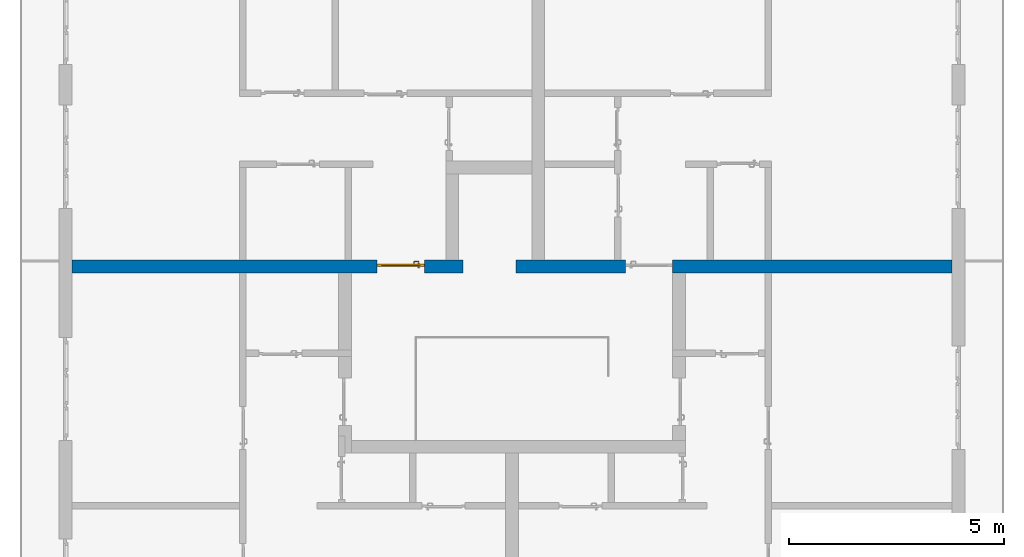
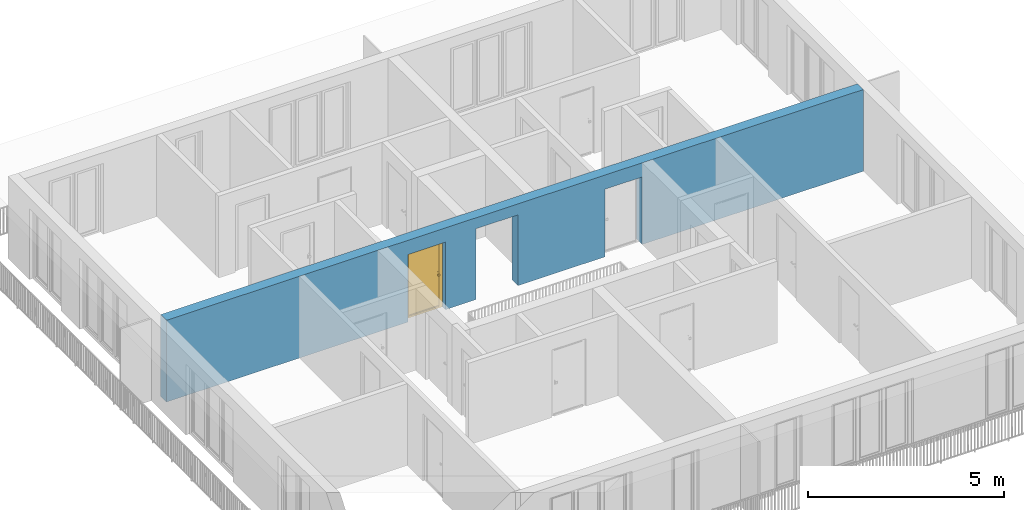
# One storey, part 16 of 54: 1 door, 1 wall, 3 openings.
"""IFC4 building model written with IfcOpenShell, lengths in metres."""

from ifc_helpers import new_model, entity, si_unit, converted_unit, derived_unit, direction, frame, origin_with_axes, place, context, subcontext, project, spatial, polygons, source, transform, mapped, material, type_object, element, fill, save


model = new_model("IFC4")

# Units and contexts
model_context = context("Model", 3, precision=1e-05, world=origin_with_axes(), true_north=direction((0.0, 1.0)))
body_context = subcontext(model_context, "Body", "Model", "MODEL_VIEW")
ifc_project = project(units=[si_unit("LENGTHUNIT", "METRE"), si_unit("AREAUNIT", "SQUARE_METRE"), si_unit("VOLUMEUNIT", "CUBIC_METRE"), converted_unit("PLANEANGLEUNIT", "DEGREE", entity("IfcPlaneAngleMeasure", 0.0174532925199), si_unit("PLANEANGLEUNIT", "RADIAN"), dimensions=[0, 0, 0, 0, 0, 0, 0]), converted_unit("TIMEUNIT", "Year", entity("IfcTimeMeasure", 31556926.0), si_unit("TIMEUNIT", "SECOND"), dimensions=[0, 0, 1, 0, 0, 0, 0]), si_unit("MASSUNIT", "GRAM", prefix="KILO"), si_unit("THERMODYNAMICTEMPERATUREUNIT", "DEGREE_CELSIUS"), si_unit("LUMINOUSINTENSITYUNIT", "LUMEN"), si_unit("ENERGYUNIT", "JOULE", prefix="MEGA"), derived_unit("THERMALCONDUCTANCEUNIT", [(si_unit("POWERUNIT", "WATT"), 1), (si_unit("LENGTHUNIT", "METRE"), -1), (si_unit("THERMODYNAMICTEMPERATUREUNIT", "KELVIN"), -1)]), derived_unit("SPECIFICHEATCAPACITYUNIT", [(si_unit("ENERGYUNIT", "JOULE"), 1), (si_unit("MASSUNIT", "GRAM", prefix="KILO"), -1), (si_unit("THERMODYNAMICTEMPERATUREUNIT", "KELVIN"), -1)]), derived_unit("MASSDENSITYUNIT", [(si_unit("MASSUNIT", "GRAM", prefix="KILO"), 1), (si_unit("VOLUMEUNIT", "CUBIC_METRE"), -1)])], contexts=[model_context])

# Site, building, storey
site_placement = place(None, origin_with_axes())
site = spatial("IfcSite", under=ifc_project, at=site_placement, CompositionType="ELEMENT")
building_placement = place(site_placement, origin_with_axes())
building = spatial("IfcBuilding", under=site, at=building_placement, CompositionType="ELEMENT")
storey_placement = place(building_placement, frame((0.0, 0.0, 9.18), z_axis=(0.0, 0.0, 1.0), x_axis=(1.0, 0.0, 0.0)))
storey = spatial("IfcBuildingStorey", under=building, at=storey_placement, Name="3. Geschoss", CompositionType="ELEMENT", Elevation=9.18)

# Wall, openings, door
ifc_material = material()
wall_type = type_object("IfcWallType", Name="300", PredefinedType="NOTDEFINED")
wall_placement = place(storey_placement, frame((-11.7421993804, 1.37118776896, 0.0), z_axis=(0.0, 0.0, 1.0), x_axis=(1.0, 0.0, 0.0)))
wall = element("IfcWall", 1, at=wall_placement, inside=storey, type_object=wall_type, material=ifc_material, Name="Wand-001", PredefinedType="NOTDEFINED", context=body_context, shape_type="Tessellation", body=[
    polygons([(9.4, 0.3, 2.2), (9.4, 0.3, 0.0), (8.5, 0.3, 0.0), (8.5, 0.3, 2.1), (7.4, 0.3, 2.1), (7.4, 0.3, 0.0), (0.3, 0.3, 0.0), (0.3, 0.3, 2.54), (20.78, 0.3, 2.54), (20.78, 0.3, 0.0), (14.28, 0.3, 0.0), (14.28, 0.3, 2.1), (13.18, 0.3, 2.1), (13.18, 0.3, 0.0), (10.63, 0.3, 0.0), (10.63, 0.3, 2.2), (9.4, 0.0, 2.2), (9.4, 0.0, 0.0), (8.5, 0.0, 0.0), (8.5, 0.0, 2.1), (7.4, 0.0, 2.1), (7.4, 0.0, 0.0), (0.3, 0.0, 0.0), (0.3, 0.0, 2.54), (20.78, 0.0, 2.54), (20.78, 0.0, 0.0), (14.28, 0.0, 0.0), (14.28, 0.0, 2.1), (13.18, 0.0, 2.1), (13.18, 0.0, 0.0), (10.63, 0.0, 0.0), (10.63, 0.0, 2.2)], [[[1, 2, 3, 4, 5, 6, 7, 8, 9, 10, 11, 12, 13, 14, 15, 16]], [[2, 1, 17, 18]], [[2, 18, 19, 3]], [[20, 4, 3, 19]], [[21, 5, 4, 20]], [[22, 6, 5, 21]], [[7, 6, 22, 23]], [[24, 8, 7, 23]], [[25, 9, 8, 24]], [[9, 25, 26, 10]], [[10, 26, 27, 11]], [[11, 27, 28, 12]], [[12, 28, 29, 13]], [[13, 29, 30, 14]], [[31, 15, 14, 30]], [[16, 15, 31, 32]], [[1, 16, 32, 17]], [[32, 31, 30, 29, 28, 27, 26, 25, 24, 23, 22, 21, 20, 19, 18, 17]]], closed=True),
])
opening_1_placement = place(wall_placement, frame((7.95, 0.0, 0.0), z_axis=(0.0, 0.0, 1.0), x_axis=(1.0, 0.0, 0.0)))
opening_1 = element("IfcOpeningElement", 2, at=opening_1_placement, cuts=wall, context=body_context, identifier="Reference", shape_type="Tessellation", body=[
    polygons([(0.55, 0.15, 0.0), (0.55, 0.15, 2.1), (0.55, -0.001, 2.1), (0.55, -0.001, 0.0), (0.55, 0.301, 0.0), (0.55, 0.301, 2.1), (-0.55, 0.15, 2.1), (-0.55, -0.001, 2.1), (-0.55, 0.301, 2.1), (-0.55, -0.001, 0.0), (-0.55, 0.15, 0.0), (-0.55, 0.301, 0.0)], [[[1, 2, 3, 4]], [[2, 1, 5, 6]], [[7, 8, 3, 2, 6, 9]], [[8, 10, 4, 3]], [[1, 4, 10, 11, 12, 5]], [[6, 5, 12, 9]], [[7, 11, 10, 8]], [[11, 7, 9, 12]]], closed=True),
])
opening_2_placement = place(wall_placement, frame((13.73, 0.0, 0.0), z_axis=(0.0, 0.0, 1.0), x_axis=(1.0, 0.0, 0.0)))
element("IfcOpeningElement", 3, at=opening_2_placement, cuts=wall, context=body_context, identifier="Reference", shape_type="Tessellation", body=[
    polygons([(0.55, 0.15, 0.0), (0.55, 0.15, 2.1), (0.55, -0.001, 2.1), (0.55, -0.001, 0.0), (0.55, 0.301, 0.0), (0.55, 0.301, 2.1), (-0.55, 0.15, 2.1), (-0.55, -0.001, 2.1), (-0.55, 0.301, 2.1), (-0.55, -0.001, 0.0), (-0.55, 0.15, 0.0), (-0.55, 0.301, 0.0)], [[[1, 2, 3, 4]], [[2, 1, 5, 6]], [[7, 8, 3, 2, 6, 9]], [[8, 10, 4, 3]], [[1, 4, 10, 11, 12, 5]], [[6, 5, 12, 9]], [[7, 11, 10, 8]], [[11, 7, 9, 12]]], closed=True),
])
opening_3_placement = place(wall_placement, frame((10.015, 0.0, 0.0), z_axis=(0.0, 0.0, 1.0), x_axis=(1.0, 0.0, 0.0)))
element("IfcOpeningElement", 4, at=opening_3_placement, cuts=wall, context=body_context, identifier="Reference", shape_type="Tessellation", body=[
    polygons([(-0.615, -0.001, 2.2), (-0.615, -0.001, 0.0), (0.615, -0.001, 0.0), (0.615, -0.001, 2.2), (-0.615, 0.301, 2.2), (-0.615, 0.301, 0.0), (0.615, 0.301, 0.0), (0.615, 0.301, 2.2)], [[[1, 2, 3, 4]], [[5, 6, 2, 1]], [[6, 7, 3, 2]], [[7, 8, 4, 3]], [[8, 5, 1, 4]], [[7, 6, 5, 8]]], closed=True),
])
door_type = type_object("IfcDoorType", Name="Eingang 01 1-Fl 26", OperationType="SINGLE_SWING_LEFT", PredefinedType="DOOR")
shared_shape = source(origin_with_axes(), body_context, "Body", "Tessellation", [
    polygons([(-0.55, -0.05, 0.0), (-0.55, -0.05, 2.1), (-0.55, -0.03, 2.1), (-0.55, -0.03, 0.0), (-0.45, -0.05, 0.0), (-0.45, -0.05, 2.0), (-0.1301, -0.05, 2.0), (-0.0001, -0.05, 2.0), (0.45, -0.05, 2.0), (0.45, -0.05, 0.0), (0.55, -0.05, 0.0), (0.55, -0.05, 2.1), (0.55, -0.03, 2.1), (0.55, -0.03, 0.0), (0.45, -0.03, 0.0), (0.45, -0.03, 2.0), (-0.0001, -0.03, 2.0), (-0.1301, -0.03, 2.0), (-0.45, -0.03, 2.0), (-0.45, -0.03, 0.0)], [[[1, 2, 3, 4]], [[1, 5, 6, 7, 8, 9, 10, 11, 12, 2]], [[2, 12, 13, 3]], [[4, 3, 13, 14, 15, 16, 17, 18, 19, 20]], [[5, 1, 4, 20]], [[6, 5, 20, 19]], [[7, 6, 19, 18]], [[8, 7, 18, 17]], [[9, 8, 17, 16]], [[10, 9, 16, 15]], [[11, 10, 15, 14]], [[12, 11, 14, 13]]], closed=True),
    polygons([(-0.55, -0.03, 0.0), (-0.55, -0.03, 2.1), (-0.55, 0.0, 2.1), (-0.55, 0.0, 0.0), (-0.48, -0.03, 0.0), (-0.48, -0.03, 2.03), (-0.1001, -0.03, 2.03), (-0.0301, -0.03, 2.03), (0.48, -0.03, 2.03), (0.48, -0.03, 0.0), (0.55, -0.03, 0.0), (0.55, -0.03, 2.1), (0.55, 0.0, 2.1), (0.55, 0.0, 0.0), (0.48, 0.0, 0.0), (0.48, 0.0, 2.03), (-0.0301, 0.0, 2.03), (-0.1001, 0.0, 2.03), (-0.48, 0.0, 2.03), (-0.48, 0.0, 0.0)], [[[1, 2, 3, 4]], [[1, 5, 6, 7, 8, 9, 10, 11, 12, 2]], [[2, 12, 13, 3]], [[4, 3, 13, 14, 15, 16, 17, 18, 19, 20]], [[5, 1, 4, 20]], [[6, 5, 20, 19]], [[7, 6, 19, 18]], [[8, 7, 18, 17]], [[9, 8, 17, 16]], [[10, 9, 16, 15]], [[11, 10, 15, 14]], [[12, 11, 14, 13]]], closed=True),
    polygons([(-0.48, 0.01, 0.0), (-0.48, 0.01, 2.03), (0.48, 0.01, 2.03), (0.48, 0.01, 0.0), (-0.48, -0.03, 0.0), (-0.48, -0.03, 2.03), (0.48, -0.03, 2.03), (0.48, -0.03, 0.0)], [[[1, 2, 3, 4]], [[1, 5, 6, 2]], [[2, 6, 7, 3]], [[3, 7, 8, 4]], [[4, 8, 5, 1]], [[8, 7, 6, 5]]], closed=True),
    polygons([(-0.445, -0.05, 0.0), (0.445, -0.05, 0.0), (0.445, -0.05, 0.05), (-0.445, -0.05, 0.05), (-0.445, -0.03, 0.0), (0.445, -0.03, 0.0), (0.445, -0.03, 0.07), (0.445, -0.035, 0.07), (-0.445, -0.035, 0.07), (-0.445, -0.03, 0.07)], [[[1, 2, 3, 4]], [[5, 6, 2, 1]], [[2, 6, 7, 8, 3]], [[4, 3, 8, 9]], [[1, 4, 9, 10, 5]], [[10, 7, 6, 5]], [[9, 8, 7, 10]]], closed=True),
    polygons([(0.4335, 0.02, 1.0733826859), (0.42, 0.02, 1.077), (0.42, 0.0199, 1.077), (0.4335, 0.0199, 1.0733826859), (0.443382685902, 0.02, 1.0635), (0.447, 0.02, 1.05), (0.443382685902, 0.02, 1.0365), (0.4335, 0.02, 1.0266173141), (0.42, 0.02, 1.023), (0.4065, 0.02, 1.0266173141), (0.396617314098, 0.02, 1.0365), (0.393, 0.02, 1.05), (0.396617314098, 0.02, 1.0635), (0.4065, 0.02, 1.0733826859), (0.4065, 0.0199, 1.0733826859), (0.42, 0.0101, 1.077), (0.4335, 0.0101, 1.0733826859), (0.443382685902, 0.0199, 1.0635), (0.447, 0.0199, 1.05), (0.443382685902, 0.0199, 1.0365), (0.4335, 0.0199, 1.0266173141), (0.42, 0.0199, 1.023), (0.4065, 0.0199, 1.0266173141), (0.396617314098, 0.0199, 1.0365), (0.393, 0.0199, 1.05), (0.396617314098, 0.0199, 1.0635), (0.4065, 0.0101, 1.0733826859), (0.42, 0.01, 1.077), (0.4335, 0.01, 1.0733826859), (0.443382685902, 0.0101, 1.0635), (0.447, 0.0101, 1.05), (0.443382685902, 0.0101, 1.0365), (0.4335, 0.0101, 1.0266173141), (0.42, 0.0101, 1.023), (0.4065, 0.0101, 1.0266173141), (0.396617314098, 0.0101, 1.0365), (0.393, 0.0101, 1.05), (0.396617314098, 0.0101, 1.0635), (0.4065, 0.01, 1.0733826859), (0.396617314098, 0.01, 1.0635), (0.393, 0.01, 1.05), (0.396617314098, 0.01, 1.0365), (0.4065, 0.01, 1.0266173141), (0.42, 0.01, 1.023), (0.4335, 0.01, 1.0266173141), (0.443382685902, 0.01, 1.0365), (0.447, 0.01, 1.05), (0.443382685902, 0.01, 1.0635)], [[[1, 2, 3, 4]], [[2, 1, 5, 6, 7, 8, 9, 10, 11, 12, 13, 14]], [[2, 14, 15, 3]], [[4, 3, 16, 17]], [[5, 1, 4, 18]], [[6, 5, 18, 19]], [[7, 6, 19, 20]], [[8, 7, 20, 21]], [[9, 8, 21, 22]], [[10, 9, 22, 23]], [[11, 10, 23, 24]], [[12, 11, 24, 25]], [[13, 12, 25, 26]], [[14, 13, 26, 15]], [[3, 15, 27, 16]], [[17, 16, 28, 29]], [[18, 4, 17, 30]], [[19, 18, 30, 31]], [[20, 19, 31, 32]], [[21, 20, 32, 33]], [[22, 21, 33, 34]], [[23, 22, 34, 35]], [[24, 23, 35, 36]], [[25, 24, 36, 37]], [[26, 25, 37, 38]], [[15, 26, 38, 27]], [[16, 27, 39, 28]], [[28, 39, 40, 41, 42, 43, 44, 45, 46, 47, 48, 29]], [[30, 17, 29, 48]], [[31, 30, 48, 47]], [[32, 31, 47, 46]], [[33, 32, 46, 45]], [[34, 33, 45, 44]], [[35, 34, 44, 43]], [[36, 35, 43, 42]], [[37, 36, 42, 41]], [[38, 37, 41, 40]], [[27, 38, 40, 39]]], closed=True),
    polygons([(0.412532169224, 0.019, 0.959692280177), (0.413279754556, 0.019, 0.961639806549), (0.40705, 0.019, 0.972430057958), (0.397569942042, 0.019, 0.96295), (0.415, 0.019, 0.952886751346), (0.415, 0.019, 0.9544), (0.412532169224, 0.02, 0.959692280177), (0.413279754556, 0.02, 0.961639806549), (0.414624817685, 0.02, 0.965143815798), (0.414624817685, 0.019, 0.965143815798), (0.42, 0.019, 0.967425445323), (0.42, 0.019, 0.9759), (0.407, 0.019, 0.972516660498), (0.397483339502, 0.019, 0.963), (0.415, 0.019, 0.95), (0.3941, 0.019, 0.95), (0.415, 0.019, 0.947113248654), (0.415, 0.019, 0.941339745962), (0.415, 0.019, 0.9375), (0.415, 0.02, 0.9375), (0.415, 0.02, 0.941339745962), (0.415, 0.02, 0.947113248654), (0.415, 0.02, 0.95), (0.415, 0.02, 0.952886751346), (0.415, 0.02, 0.9544), (0.396703916638, 0.02, 0.96345), (0.40655, 0.02, 0.973296083362), (0.42, 0.02, 0.9769), (0.42, 0.02, 0.967425445323), (0.425375182315, 0.019, 0.965143815798), (0.426720245444, 0.019, 0.961639806549), (0.43295, 0.019, 0.972430057958), (0.42, 0.019, 0.976), (0.407, 0.0189, 0.972516660498), (0.397483339502, 0.0189, 0.963), (0.394, 0.019, 0.95), (0.397569942042, 0.019, 0.93705), (0.40705, 0.019, 0.927569942042), (0.42, 0.019, 0.9241), (0.42, 0.019, 0.9325), (0.416464466094, 0.019, 0.933964466094), (0.416464466094, 0.02, 0.933964466094), (0.42, 0.02, 0.9231), (0.40655, 0.02, 0.926703916638), (0.42, 0.02, 0.9325), (0.396703916638, 0.02, 0.93655), (0.3931, 0.02, 0.95), (0.396617314098, 0.02, 0.9635), (0.4065, 0.02, 0.973382685902), (0.42, 0.02, 0.977), (0.425375182315, 0.02, 0.965143815798), (0.43345, 0.02, 0.973296083362), (0.426720245444, 0.02, 0.961639806549), (0.427467830776, 0.02, 0.959692280177), (0.427467830776, 0.019, 0.959692280177), (0.425, 0.019, 0.9544), (0.425, 0.019, 0.952886751346), (0.442430057958, 0.019, 0.96295), (0.433, 0.019, 0.972516660498), (0.42, 0.0189, 0.976), (0.407, 0.0101, 0.972516660498), (0.397483339502, 0.0101, 0.963), (0.394, 0.0189, 0.95), (0.397483339502, 0.019, 0.937), (0.407, 0.019, 0.927483339502), (0.42, 0.019, 0.924), (0.43295, 0.019, 0.927569942042), (0.425, 0.019, 0.941339745962), (0.425, 0.019, 0.9375), (0.423535533906, 0.019, 0.933964466094), (0.42, 0.02, 0.923), (0.4065, 0.02, 0.926617314098), (0.43345, 0.02, 0.926703916638), (0.423535533906, 0.02, 0.933964466094), (0.425, 0.02, 0.9375), (0.425, 0.02, 0.941339745962), (0.396617314098, 0.02, 0.9365), (0.393, 0.02, 0.95), (0.396617314098, 0.0199, 0.9635), (0.4065, 0.0199, 0.973382685902), (0.42, 0.0199, 0.977), (0.4335, 0.02, 0.973382685902), (0.443296083362, 0.02, 0.96345), (0.425, 0.02, 0.952886751346), (0.425, 0.02, 0.9544), (0.425, 0.02, 0.95), (0.425, 0.02, 0.947113248654), (0.425, 0.019, 0.947113248654), (0.425, 0.019, 0.95), (0.4459, 0.019, 0.95), (0.442516660498, 0.019, 0.963), (0.433, 0.0189, 0.972516660498), (0.42, 0.0101, 0.976), (0.407, 0.01, 0.972516660498), (0.397483339502, 0.01, 0.963), (0.394, 0.0101, 0.95), (0.397483339502, 0.0189, 0.937), (0.407, 0.0189, 0.927483339502), (0.42, 0.0189, 0.924), (0.433, 0.019, 0.927483339502), (0.442430057958, 0.019, 0.93705), (0.42, 0.0199, 0.923), (0.4065, 0.0199, 0.926617314098), (0.4335, 0.02, 0.926617314098), (0.443296083362, 0.02, 0.93655), (0.396617314098, 0.0199, 0.9365), (0.393, 0.0199, 0.95), (0.396617314098, 0.0101, 0.9635), (0.4065, 0.0101, 0.973382685902), (0.42, 0.0101, 0.977), (0.4335, 0.0199, 0.973382685902), (0.443382685902, 0.02, 0.9635), (0.4469, 0.02, 0.95), (0.446, 0.019, 0.95), (0.442516660498, 0.0189, 0.963), (0.433, 0.0101, 0.972516660498), (0.42, 0.01, 0.976), (0.40695, 0.01, 0.972603263039), (0.397396736961, 0.01, 0.96305), (0.394, 0.01, 0.95), (0.397483339502, 0.0101, 0.937), (0.407, 0.0101, 0.927483339502), (0.42, 0.0101, 0.924), (0.433, 0.0189, 0.927483339502), (0.442516660498, 0.019, 0.937), (0.42, 0.0101, 0.923), (0.4065, 0.0101, 0.926617314098), (0.4335, 0.0199, 0.926617314098), (0.443382685902, 0.02, 0.9365), (0.396617314098, 0.0101, 0.9365), (0.393, 0.0101, 0.95), (0.396617314098, 0.01, 0.9635), (0.4065, 0.01, 0.973382685902), (0.42, 0.01, 0.977), (0.4335, 0.0101, 0.973382685902), (0.443382685902, 0.0199, 0.9635), (0.447, 0.02, 0.95), (0.446, 0.0189, 0.95), (0.442516660498, 0.0101, 0.963), (0.433, 0.01, 0.972516660498), (0.42, 0.01, 0.9761), (0.40655, 0.01, 0.973296083362), (0.396703916638, 0.01, 0.96345), (0.3939, 0.01, 0.95), (0.397483339502, 0.01, 0.937), (0.407, 0.01, 0.927483339502), (0.42, 0.01, 0.924), (0.433, 0.0101, 0.927483339502), (0.442516660498, 0.0189, 0.937), (0.42, 0.01, 0.923), (0.4065, 0.01, 0.926617314098), (0.4335, 0.0101, 0.926617314098), (0.443382685902, 0.0199, 0.9365), (0.396617314098, 0.01, 0.9365), (0.393, 0.01, 0.95), (0.42, 0.01, 0.9769), (0.4335, 0.01, 0.973382685902), (0.443382685902, 0.0101, 0.9635), (0.447, 0.0199, 0.95), (0.446, 0.0101, 0.95), (0.442516660498, 0.01, 0.963), (0.43305, 0.01, 0.972603263039), (0.3931, 0.01, 0.95), (0.397396736961, 0.01, 0.93695), (0.40695, 0.01, 0.927396736961), (0.42, 0.01, 0.9239), (0.433, 0.01, 0.927483339502), (0.442516660498, 0.0101, 0.937), (0.42, 0.01, 0.9231), (0.40655, 0.01, 0.926703916638), (0.4335, 0.01, 0.926617314098), (0.443382685902, 0.0101, 0.9365), (0.396703916638, 0.01, 0.93655), (0.43345, 0.01, 0.973296083362), (0.443382685902, 0.01, 0.9635), (0.447, 0.0101, 0.95), (0.446, 0.01, 0.95), (0.442603263039, 0.01, 0.96305), (0.43305, 0.01, 0.927396736961), (0.442516660498, 0.01, 0.937), (0.43345, 0.01, 0.926703916638), (0.443382685902, 0.01, 0.9365), (0.443296083362, 0.01, 0.96345), (0.447, 0.01, 0.95), (0.4461, 0.01, 0.95), (0.442603263039, 0.01, 0.93695), (0.443296083362, 0.01, 0.93655), (0.4469, 0.01, 0.95)], [[[1, 2, 3, 4, 5, 6]], [[1, 7, 8, 9, 10, 2]], [[10, 11, 12, 3, 2]], [[4, 3, 13, 14]], [[15, 5, 4, 16]], [[6, 5, 15, 17, 18, 19, 20, 21, 22, 23, 24, 25]], [[6, 25, 7, 1]], [[7, 25, 24, 26, 27, 8]], [[9, 8, 27, 28, 29]], [[10, 9, 29, 11]], [[30, 31, 32, 12, 11]], [[3, 12, 33, 13]], [[14, 13, 34, 35]], [[16, 4, 14, 36]], [[17, 15, 16, 37]], [[18, 17, 37, 38]], [[38, 39, 40, 41, 19, 18]], [[19, 41, 42, 20]], [[43, 44, 21, 20, 42, 45]], [[22, 21, 44, 46]], [[23, 22, 46, 47]], [[24, 23, 47, 26]], [[48, 49, 27, 26]], [[49, 50, 28, 27]], [[51, 29, 28, 52, 53]], [[11, 29, 51, 30]], [[30, 51, 53, 54, 55, 31]], [[55, 56, 57, 58, 32, 31]], [[12, 32, 59, 33]], [[13, 33, 60, 34]], [[35, 34, 61, 62]], [[36, 14, 35, 63]], [[37, 16, 36, 64]], [[38, 37, 64, 65]], [[39, 38, 65, 66]], [[39, 67, 68, 69, 70, 40]], [[41, 40, 45, 42]], [[71, 72, 44, 43]], [[73, 43, 45, 74, 75, 76]], [[72, 77, 46, 44]], [[77, 78, 47, 46]], [[78, 48, 26, 47]], [[79, 80, 49, 48]], [[80, 81, 50, 49]], [[50, 82, 52, 28]], [[54, 53, 52, 83, 84, 85]], [[55, 54, 85, 56]], [[85, 84, 86, 87, 76, 75, 69, 68, 88, 89, 57, 56]], [[57, 89, 90, 58]], [[32, 58, 91, 59]], [[33, 59, 92, 60]], [[34, 60, 93, 61]], [[62, 61, 94, 95]], [[63, 35, 62, 96]], [[64, 36, 63, 97]], [[65, 64, 97, 98]], [[66, 65, 98, 99]], [[67, 39, 66, 100]], [[88, 68, 67, 101]], [[70, 69, 75, 74]], [[40, 70, 74, 45]], [[102, 103, 72, 71]], [[104, 71, 43, 73]], [[76, 87, 105, 73]], [[103, 106, 77, 72]], [[106, 107, 78, 77]], [[107, 79, 48, 78]], [[108, 109, 80, 79]], [[109, 110, 81, 80]], [[81, 111, 82, 50]], [[82, 112, 83, 52]], [[86, 84, 83, 113]], [[87, 86, 113, 105]], [[89, 88, 101, 90]], [[58, 90, 114, 91]], [[59, 91, 115, 92]], [[60, 92, 116, 93]], [[61, 93, 117, 94]], [[95, 94, 118, 119]], [[96, 62, 95, 120]], [[97, 63, 96, 121]], [[98, 97, 121, 122]], [[99, 98, 122, 123]], [[100, 66, 99, 124]], [[101, 67, 100, 125]], [[126, 127, 103, 102]], [[128, 102, 71, 104]], [[129, 104, 73, 105]], [[127, 130, 106, 103]], [[130, 131, 107, 106]], [[131, 108, 79, 107]], [[132, 133, 109, 108]], [[133, 134, 110, 109]], [[110, 135, 111, 81]], [[111, 136, 112, 82]], [[112, 137, 113, 83]], [[137, 129, 105, 113]], [[90, 101, 125, 114]], [[91, 114, 138, 115]], [[92, 115, 139, 116]], [[93, 116, 140, 117]], [[94, 117, 141, 118]], [[119, 118, 142, 143]], [[120, 95, 119, 144]], [[121, 96, 120, 145]], [[122, 121, 145, 146]], [[123, 122, 146, 147]], [[124, 99, 123, 148]], [[125, 100, 124, 149]], [[150, 151, 127, 126]], [[152, 126, 102, 128]], [[153, 128, 104, 129]], [[151, 154, 130, 127]], [[154, 155, 131, 130]], [[155, 132, 108, 131]], [[143, 142, 133, 132]], [[142, 156, 134, 133]], [[134, 157, 135, 110]], [[135, 158, 136, 111]], [[136, 159, 137, 112]], [[159, 153, 129, 137]], [[114, 125, 149, 138]], [[115, 138, 160, 139]], [[116, 139, 161, 140]], [[117, 140, 162, 141]], [[118, 141, 156, 142]], [[144, 119, 143, 163]], [[145, 120, 144, 164]], [[146, 145, 164, 165]], [[147, 146, 165, 166]], [[148, 123, 147, 167]], [[149, 124, 148, 168]], [[169, 170, 151, 150]], [[171, 150, 126, 152]], [[172, 152, 128, 153]], [[170, 173, 154, 151]], [[173, 163, 155, 154]], [[163, 143, 132, 155]], [[156, 174, 157, 134]], [[157, 175, 158, 135]], [[158, 176, 159, 136]], [[176, 172, 153, 159]], [[138, 149, 168, 160]], [[139, 160, 177, 161]], [[140, 161, 178, 162]], [[141, 162, 174, 156]], [[164, 144, 163, 173]], [[165, 164, 173, 170]], [[166, 165, 170, 169]], [[167, 147, 166, 179]], [[168, 148, 167, 180]], [[181, 169, 150, 171]], [[182, 171, 152, 172]], [[174, 183, 175, 157]], [[175, 184, 176, 158]], [[184, 182, 172, 176]], [[160, 168, 180, 177]], [[161, 177, 185, 178]], [[162, 178, 183, 174]], [[179, 166, 169, 181]], [[180, 167, 179, 186]], [[187, 181, 171, 182]], [[183, 188, 184, 175]], [[188, 187, 182, 184]], [[177, 180, 186, 185]], [[178, 185, 188, 183]], [[186, 179, 181, 187]], [[185, 186, 187, 188]]], closed=True),
    polygons([(0.43, 0.02, 1.05), (0.427071067812, 0.02, 1.04292893219), (0.427071067812, 0.050696439392, 1.04292893219), (0.43, 0.0509849140336, 1.05), (0.42, 0.02, 1.04), (0.42, 0.05, 1.04), (0.425518993221, 0.0584992452783, 1.04292893219), (0.428277987014, 0.0596420579258, 1.05), (0.427071067812, 0.02, 1.05707106781), (0.427071067812, 0.050696439392, 1.05707106781), (0.412928932188, 0.02, 1.04292893219), (0.412928932188, 0.049303560608, 1.04292893219), (0.418858192988, 0.0557402514855, 1.04), (0.420704557509, 0.0657045575088, 1.04292893219), (0.422816199938, 0.0678161999379, 1.05), (0.425518993221, 0.0584992452783, 1.05707106781), (0.42, 0.02, 1.06), (0.42, 0.05, 1.06), (0.41, 0.02, 1.05), (0.41, 0.0490150859664, 1.05), (0.412197392755, 0.0529812576926, 1.04292893219), (0.415606601718, 0.0606066017178, 1.04), (0.413499245278, 0.0705189932208, 1.04292893219), (0.414642057926, 0.0732779870137, 1.05), (0.420704557509, 0.0657045575088, 1.05707106781), (0.418858192988, 0.0557402514855, 1.06), (0.412928932188, 0.02, 1.05707106781), (0.412928932188, 0.049303560608, 1.05707106781), (0.409438398962, 0.0518384450452, 1.05), (0.410508645927, 0.0555086459268, 1.04292893219), (0.410740251485, 0.0638581929877, 1.04), (0.405696439392, 0.0720710678119, 1.04292893219), (0.405984914034, 0.075, 1.05), (0.413499245278, 0.0705189932208, 1.05707106781), (0.415606601718, 0.0606066017178, 1.06), (0.412197392755, 0.0529812576926, 1.05707106781), (0.408397003498, 0.0533970034977, 1.05), (0.407981257693, 0.0571973927545, 1.04292893219), (0.405, 0.065, 1.04), (0.324303560608, 0.0720710678119, 1.04292893219), (0.324015085966, 0.075, 1.05), (0.405696439392, 0.0720710678119, 1.05707106781), (0.410740251485, 0.0638581929877, 1.06), (0.410508645927, 0.0555086459268, 1.05707106781), (0.406838445045, 0.0544383989617, 1.05), (0.404303560608, 0.0579289321881, 1.04292893219), (0.325, 0.065, 1.04), (0.316500754722, 0.0705189932208, 1.04292893219), (0.315357942074, 0.0732779870137, 1.05), (0.324303560608, 0.0720710678119, 1.05707106781), (0.405, 0.065, 1.06), (0.407981257693, 0.0571973927545, 1.05707106781), (0.404015085966, 0.055, 1.05), (0.325696439392, 0.0579289321881, 1.04292893219), (0.319259748515, 0.0638581929877, 1.04), (0.309295442491, 0.0657045575088, 1.04292893219), (0.307183800062, 0.0678161999379, 1.05), (0.316500754722, 0.0705189932208, 1.05707106781), (0.325, 0.065, 1.06), (0.404303560608, 0.0579289321881, 1.05707106781), (0.325984914034, 0.055, 1.05), (0.322018742307, 0.0571973927545, 1.04292893219), (0.314393398282, 0.0606066017178, 1.04), (0.304481006779, 0.0584992452783, 1.04292893219), (0.301722012986, 0.0596420579258, 1.05), (0.309295442491, 0.0657045575088, 1.05707106781), (0.319259748515, 0.0638581929877, 1.06), (0.325696439392, 0.0579289321881, 1.05707106781), (0.323161554955, 0.0544383989617, 1.05), (0.319491354073, 0.0555086459268, 1.04292893219), (0.311141807012, 0.0557402514855, 1.04), (0.302928932188, 0.050696439392, 1.04292893219), (0.3, 0.0509849140336, 1.05), (0.304481006779, 0.0584992452783, 1.05707106781), (0.314393398282, 0.0606066017178, 1.06), (0.322018742307, 0.0571973927545, 1.05707106781), (0.321602996502, 0.0533970034977, 1.05), (0.317802607245, 0.0529812576926, 1.04292893219), (0.31, 0.05, 1.04), (0.302928932188, 0.02, 1.04292893219), (0.3, 0.02, 1.05), (0.302928932188, 0.050696439392, 1.05707106781), (0.311141807012, 0.0557402514855, 1.06), (0.319491354073, 0.0555086459268, 1.05707106781), (0.320561601038, 0.0518384450452, 1.05), (0.317071067812, 0.049303560608, 1.04292893219), (0.31, 0.02, 1.04), (0.317071067812, 0.02, 1.04292893219), (0.32, 0.02, 1.05), (0.317071067812, 0.02, 1.05707106781), (0.31, 0.02, 1.06), (0.302928932188, 0.02, 1.05707106781), (0.31, 0.05, 1.06), (0.317802607245, 0.0529812576926, 1.05707106781), (0.32, 0.0490150859664, 1.05), (0.317071067812, 0.049303560608, 1.05707106781)], [[[1, 2, 3, 4]], [[2, 5, 6, 3]], [[4, 3, 7, 8]], [[9, 1, 4, 10]], [[5, 11, 12, 6]], [[3, 6, 13, 7]], [[8, 7, 14, 15]], [[10, 4, 8, 16]], [[17, 9, 10, 18]], [[11, 19, 20, 12]], [[6, 12, 21, 13]], [[7, 13, 22, 14]], [[15, 14, 23, 24]], [[16, 8, 15, 25]], [[18, 10, 16, 26]], [[27, 17, 18, 28]], [[19, 27, 28, 20]], [[12, 20, 29, 21]], [[13, 21, 30, 22]], [[14, 22, 31, 23]], [[24, 23, 32, 33]], [[25, 15, 24, 34]], [[26, 16, 25, 35]], [[28, 18, 26, 36]], [[20, 28, 36, 29]], [[21, 29, 37, 30]], [[22, 30, 38, 31]], [[23, 31, 39, 32]], [[33, 32, 40, 41]], [[34, 24, 33, 42]], [[35, 25, 34, 43]], [[36, 26, 35, 44]], [[29, 36, 44, 37]], [[30, 37, 45, 38]], [[31, 38, 46, 39]], [[32, 39, 47, 40]], [[41, 40, 48, 49]], [[42, 33, 41, 50]], [[43, 34, 42, 51]], [[44, 35, 43, 52]], [[37, 44, 52, 45]], [[38, 45, 53, 46]], [[39, 46, 54, 47]], [[40, 47, 55, 48]], [[49, 48, 56, 57]], [[50, 41, 49, 58]], [[51, 42, 50, 59]], [[52, 43, 51, 60]], [[45, 52, 60, 53]], [[46, 53, 61, 54]], [[47, 54, 62, 55]], [[48, 55, 63, 56]], [[57, 56, 64, 65]], [[58, 49, 57, 66]], [[59, 50, 58, 67]], [[60, 51, 59, 68]], [[53, 60, 68, 61]], [[54, 61, 69, 62]], [[55, 62, 70, 63]], [[56, 63, 71, 64]], [[65, 64, 72, 73]], [[66, 57, 65, 74]], [[67, 58, 66, 75]], [[68, 59, 67, 76]], [[61, 68, 76, 69]], [[62, 69, 77, 70]], [[63, 70, 78, 71]], [[64, 71, 79, 72]], [[73, 72, 80, 81]], [[74, 65, 73, 82]], [[75, 66, 74, 83]], [[76, 67, 75, 84]], [[69, 76, 84, 77]], [[70, 77, 85, 78]], [[71, 78, 86, 79]], [[72, 79, 87, 80]], [[81, 80, 87, 88, 89, 90, 91, 92]], [[82, 73, 81, 92]], [[83, 74, 82, 93]], [[84, 75, 83, 94]], [[77, 84, 94, 85]], [[78, 85, 95, 86]], [[79, 86, 88, 87]], [[86, 95, 89, 88]], [[95, 96, 90, 89]], [[96, 93, 91, 90]], [[93, 82, 92, 91]], [[94, 83, 93, 96]], [[85, 94, 96, 95]]], closed=False),
    polygons([(0.414696699141, -0.035, 1.04469669914), (0.4125, -0.035, 1.05), (0.414696699141, -0.035, 1.05530330086), (0.42, -0.035, 1.0575), (0.425303300859, -0.035, 1.05530330086), (0.4275, -0.035, 1.05), (0.425303300859, -0.035, 1.04469669914), (0.42, -0.035, 1.0425), (0.414696699141, -0.075, 1.04469669914), (0.4125, -0.075, 1.05), (0.414696699141, -0.075, 1.05530330086), (0.42, -0.075, 1.0575), (0.425303300859, -0.075, 1.05530330086), (0.4275, -0.075, 1.05), (0.425303300859, -0.075, 1.04469669914), (0.42, -0.075, 1.0425)], [[[1, 2, 3, 4, 5, 6, 7, 8]], [[1, 9, 10, 2]], [[2, 10, 11, 3]], [[3, 11, 12, 4]], [[4, 12, 13, 5]], [[5, 13, 14, 6]], [[6, 14, 15, 7]], [[7, 15, 16, 8]], [[8, 16, 9, 1]], [[9, 16, 15, 14, 13, 12, 11, 10]]], closed=True),
    polygons([(0.445, -0.03, 0.975), (0.445, -0.035, 0.975), (0.443096988313, -0.035, 0.965432914191), (0.443096988313, -0.03, 0.965432914191), (0.445, -0.03, 1.1), (0.445, -0.035, 1.1), (0.443096988313, -0.035, 1.10956708581), (0.43767766953, -0.035, 1.11767766953), (0.429567085809, -0.035, 1.12309698831), (0.42, -0.035, 1.125), (0.410432914191, -0.035, 1.12309698831), (0.40232233047, -0.035, 1.11767766953), (0.396903011687, -0.035, 1.10956708581), (0.395, -0.035, 1.1), (0.395, -0.035, 0.975), (0.396903011687, -0.035, 0.965432914191), (0.40232233047, -0.035, 0.95732233047), (0.410432914191, -0.035, 0.951903011687), (0.42, -0.035, 0.95), (0.429567085809, -0.035, 0.951903011687), (0.43767766953, -0.035, 0.95732233047), (0.43767766953, -0.03, 0.95732233047), (0.429567085809, -0.03, 0.951903011687), (0.42, -0.03, 0.95), (0.410432914191, -0.03, 0.951903011687), (0.40232233047, -0.03, 0.95732233047), (0.396903011687, -0.03, 0.965432914191), (0.395, -0.03, 0.975), (0.395, -0.03, 1.1), (0.396903011687, -0.03, 1.10956708581), (0.40232233047, -0.03, 1.11767766953), (0.410432914191, -0.03, 1.12309698831), (0.42, -0.03, 1.125), (0.429567085809, -0.03, 1.12309698831), (0.43767766953, -0.03, 1.11767766953), (0.443096988313, -0.03, 1.10956708581)], [[[1, 2, 3, 4]], [[5, 6, 2, 1]], [[2, 6, 7, 8, 9, 10, 11, 12, 13, 14, 15, 16, 17, 18, 19, 20, 21, 3]], [[4, 3, 21, 22]], [[1, 4, 22, 23, 24, 25, 26, 27, 28, 29, 30, 31, 32, 33, 34, 35, 36, 5]], [[36, 7, 6, 5]], [[35, 8, 7, 36]], [[34, 9, 8, 35]], [[33, 10, 9, 34]], [[32, 11, 10, 33]], [[31, 12, 11, 32]], [[30, 13, 12, 31]], [[29, 14, 13, 30]], [[28, 15, 14, 29]], [[27, 16, 15, 28]], [[26, 17, 16, 27]], [[25, 18, 17, 26]], [[24, 19, 18, 25]], [[23, 20, 19, 24]], [[22, 21, 20, 23]]], closed=True),
    polygons([(0.44, -0.075, 1.08), (0.44, -0.09, 1.08), (0.445, -0.09, 1.07866025404), (0.445, -0.075, 1.07866025404), (0.4, -0.075, 1.08), (0.4, -0.09, 1.08), (0.395, -0.09, 1.07866025404), (0.391339745962, -0.09, 1.075), (0.39, -0.09, 1.07), (0.39, -0.09, 1.03), (0.391339745962, -0.09, 1.025), (0.395, -0.09, 1.02133974596), (0.4, -0.09, 1.02), (0.44, -0.09, 1.02), (0.445, -0.09, 1.02133974596), (0.448660254038, -0.09, 1.025), (0.45, -0.09, 1.03), (0.45, -0.09, 1.07), (0.448660254038, -0.09, 1.075), (0.448660254038, -0.075, 1.075), (0.45, -0.075, 1.07), (0.45, -0.075, 1.03), (0.448660254038, -0.075, 1.025), (0.445, -0.075, 1.02133974596), (0.44, -0.075, 1.02), (0.4, -0.075, 1.02), (0.395, -0.075, 1.02133974596), (0.391339745962, -0.075, 1.025), (0.39, -0.075, 1.03), (0.39, -0.075, 1.07), (0.391339745962, -0.075, 1.075), (0.395, -0.075, 1.07866025404)], [[[1, 2, 3, 4]], [[5, 6, 2, 1]], [[2, 6, 7, 8, 9, 10, 11, 12, 13, 14, 15, 16, 17, 18, 19, 3]], [[4, 3, 19, 20]], [[1, 4, 20, 21, 22, 23, 24, 25, 26, 27, 28, 29, 30, 31, 32, 5]], [[32, 7, 6, 5]], [[31, 8, 7, 32]], [[30, 9, 8, 31]], [[29, 10, 9, 30]], [[28, 11, 10, 29]], [[27, 12, 11, 28]], [[26, 13, 12, 27]], [[25, 14, 13, 26]], [[24, 15, 14, 25]], [[23, 16, 15, 24]], [[22, 17, 16, 23]], [[21, 18, 17, 22]], [[20, 19, 18, 21]]], closed=True),
])
door_placement = place(opening_1_placement, frame((-0.45, 0.0, 0.0), z_axis=(0.0, 0.0, 1.0), x_axis=(1.0, 0.0, 0.0)))
door = element("IfcDoor", 5, at=door_placement, inside=storey, type_object=door_type, OverallHeight=2.1, OverallWidth=1.1, PredefinedType="DOOR", context=body_context, shape_type="MappedRepresentation", body=[
    mapped(shared_shape, transform((0.45, 0.2, 0.0))),
])
fill(opening_1, door)

save(model, "model.ifc")
